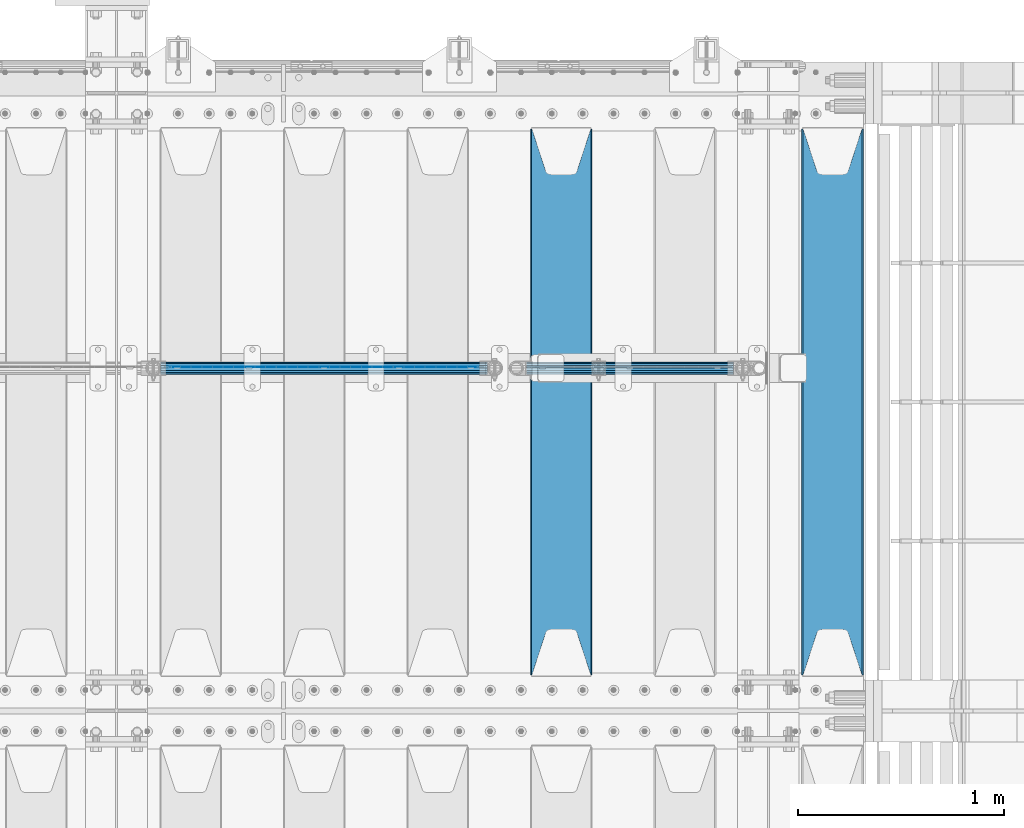
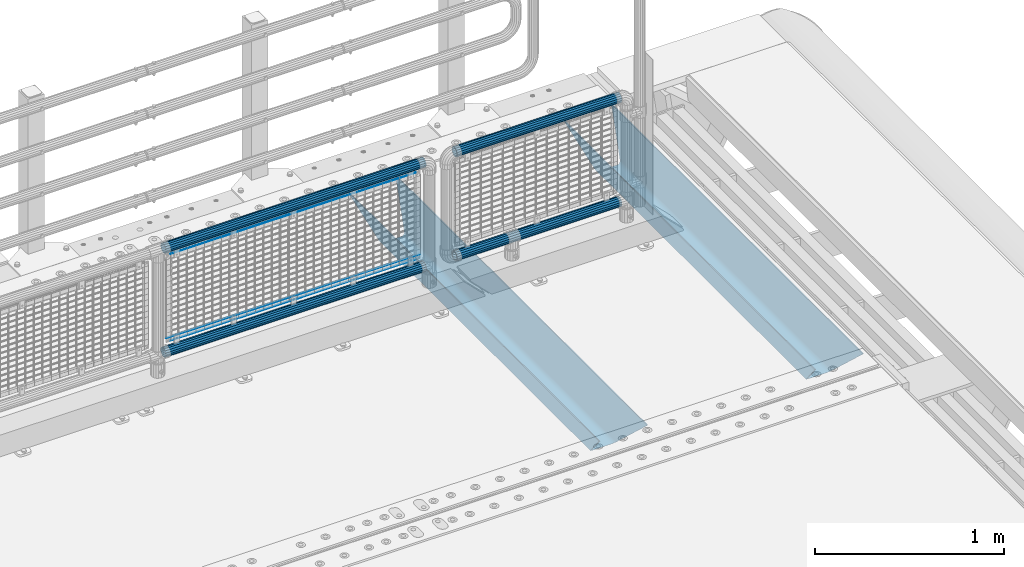
# One storey, part 125 of 240: 9 beams.
"""IFC2X3 building model written with IfcOpenShell, lengths in millimetres."""

from ifc_helpers import new_model, si_unit, frame, origin_with_axes, place, context, subcontext, project, spatial, faceted_brep, material, type_object, element, save


model = new_model("IFC2X3")

# Units and contexts
model_context = context("Model", 3, precision=1e-05, world=origin_with_axes())
body_context = subcontext(model_context, "Body", "Model", "MODEL_VIEW")
ifc_project = project(units=[si_unit("LENGTHUNIT", "METRE", prefix="MILLI"), si_unit("AREAUNIT", "SQUARE_METRE"), si_unit("VOLUMEUNIT", "CUBIC_METRE"), si_unit("MASSUNIT", "GRAM", prefix="KILO"), si_unit("TIMEUNIT", "SECOND"), si_unit("PLANEANGLEUNIT", "RADIAN"), si_unit("SOLIDANGLEUNIT", "STERADIAN"), si_unit("THERMODYNAMICTEMPERATUREUNIT", "DEGREE_CELSIUS"), si_unit("LUMINOUSINTENSITYUNIT", "LUMEN")], contexts=[model_context])

# Site, building, storey
site_placement = place(None, origin_with_axes())
site = spatial("IfcSite", under=ifc_project, at=site_placement, CompositionType="ELEMENT")
building_placement = place(site_placement, origin_with_axes())
building = spatial("IfcBuilding", under=site, at=building_placement, Name="Standard", CompositionType="ELEMENT")
storey_placement = place(building_placement, origin_with_axes())
storey = spatial("IfcBuildingStorey", under=building, at=storey_placement, Name="Undefined", CompositionType="ELEMENT", Elevation=0.0)

# Beams
ifc_material_1 = material(Name="STEEL/S355N")
beam_type_1 = type_object("IfcBeamType", PredefinedType="NOTDEFINED")
beam_1_placement = place(storey_placement, frame((56317.0, 33175.0, -115.0), z_axis=(0.0, 0.0, 1.0), x_axis=(0.0, 1.0, 0.0)))
element("IfcBeam", 1, at=beam_1_placement, inside=storey, type_object=beam_type_1, material=ifc_material_1, context=body_context, shape_type="Brep", body=[
    faceted_brep([(0.0, 150.0, 115.0), (0.0, 143.690000000002, 115.0), (2650.00000000297, 143.690000000002, 115.0), (2650.00000000297, 150.0, 115.0), (2650.00000000297, 142.059565218406, 110.000000003094), (2650.00000000297, 148.369565218403, 110.000000003094), (2441.90079219209, -80.1103600731149, -98.0992078077845), (2437.7588105432, -77.5672621345584, -102.241189456673), (2434.06523489747, -74.4080125315522, -105.934765102404), (2430.9108609509, -70.7102721255724, -109.089139048974), (2428.37322971128, -66.5649389910031, -111.626770288588), (2426.51472138055, -62.0739139532889, -113.485278619323), (2425.38102192092, -57.3475956567636, -114.618978078955), (2424.99999999987, -52.5021667386536, -115.0), (2424.99999999987, 52.5021667386536, -115.0), (2425.38102192092, 57.3475956567636, -114.618978078955), (2426.51472138055, 62.0739139532889, -113.485278619323), (2428.37322971128, 66.5649389910031, -111.626770288588), (2430.9108609509, 70.7102721255724, -109.089139048974), (2434.06523489747, 74.4080125315522, -105.934765102404), (2437.7588105432, 77.5672621345584, -102.241189456673), (2441.90079219209, 80.1103600731149, -98.0992078077846), (2446.38936140512, 81.9747917625791, -93.6106385947584), (2448.2494850041, 76.2713538057287, -91.7505149957729), (2444.62967112263, 74.76777986261, -95.3703288772456), (2441.28936334127, 72.7168944282894, -98.710636658607), (2438.31067330439, 70.1691124903809, -101.689326695487), (2435.76682334748, 67.1870637758839, -104.233176652398), (2433.72034654134, 63.8440531834931, -106.279653458539), (2432.22154950042, 60.2222587982324, -107.778450499454), (2431.30727574265, 56.4107117849126, -108.692724257221), (2430.99999999987, 52.5031078186876, -109.0), (2430.99999999987, -52.5031078186876, -109.0), (2431.30727574265, -56.4107117849126, -108.692724257221), (2432.22154950042, -60.2222587982324, -107.778450499454), (2433.72034654134, -63.8440531834931, -106.279653458539), (2435.76682334748, -67.1870637758839, -104.233176652398), (2438.31067330439, -70.1691124903809, -101.689326695487), (2441.28936334127, -72.7168944282894, -98.7106366586071), (2444.62967112263, -74.76777986261, -95.3703288772457), (2448.2494850041, -76.2713538057287, -91.7505149957729), (2650.00000000297, -142.059565218406, 110.000000003094), (2650.00000000297, -148.369565218403, 110.000000003094), (2446.38936140512, -81.9747917625791, -93.6106385947584), (2650.00000000297, -143.690000000002, 115.0), (2650.00000000297, -150.0, 115.0), (0.0, -143.690000000002, 115.0), (0.0, -150.0, 115.0), (0.0, -148.369565218258, 110.000000002667), (203.610638597427, -81.9747917625791, -93.6106385947584), (208.09920781045, -80.1103600731149, -98.0992078077845), (212.241189459342, -77.5672621345584, -102.241189456673), (215.93476510507, -74.4080125315522, -105.934765102404), (219.089139051641, -70.7102721255724, -109.089139048974), (221.626770291256, -66.5649389910031, -111.626770288588), (223.485278621989, -62.0739139532889, -113.485278619323), (224.618978081624, -57.3475956567636, -114.618978078955), (225.000000002663, -52.5021667386536, -115.0), (225.000000002663, 52.5021667386536, -115.0), (224.618978081624, 57.3475956567636, -114.618978078955), (223.485278621989, 62.0739139532889, -113.485278619323), (221.626770291256, 66.5649389910031, -111.626770288588), (219.089139051641, 70.7102721255724, -109.089139048974), (215.93476510507, 74.4080125315522, -105.934765102404), (212.241189459342, 77.5672621345584, -102.241189456673), (208.09920781045, 80.1103600731149, -98.0992078077846), (203.610638597427, 81.9747917625791, -93.6106385947584), (0.0, 148.369565218258, 110.000000002667), (0.0, 142.05956521826, 110.000000002667), (201.750514998439, 76.2713538057287, -91.7505149957729), (205.370328879908, 74.76777986261, -95.3703288772456), (208.710636661275, 72.7168944282894, -98.710636658607), (211.689326698153, 70.1691124903809, -101.689326695487), (214.233176655063, 67.1870637758839, -104.233176652398), (216.279653461206, 63.8440531834931, -106.279653458539), (217.778450502123, 60.2222587982324, -107.778450499454), (218.692724259887, 56.4107117849126, -108.692724257221), (219.000000002667, 52.5031078186876, -109.0), (219.000000002667, -52.5031078186876, -109.0), (218.692724259887, -56.4107117849126, -108.692724257221), (217.778450502123, -60.2222587982324, -107.778450499454), (216.279653461206, -63.8440531834931, -106.279653458539), (214.233176655063, -67.1870637758839, -104.233176652398), (211.689326698153, -70.1691124903809, -101.689326695487), (208.710636661275, -72.7168944282894, -98.7106366586071), (205.370328879915, -74.76777986261, -95.3703288772457), (201.750514998439, -76.2713538057287, -91.7505149957729), (0.0, -142.05956521826, 110.000000002667)], [[[0, 1, 2, 3]], [[3, 2, 4, 5]], [[6, 7, 8, 9, 10, 11, 12, 13, 14, 15, 16, 17, 18, 19, 20, 21, 22, 5, 4, 23, 24, 25, 26, 27, 28, 29, 30, 31, 32, 33, 34, 35, 36, 37, 38, 39, 40, 41, 42, 43]], [[44, 45, 42, 41]], [[46, 47, 45, 44]], [[43, 42, 45, 47, 48, 49]], [[6, 43, 49, 50]], [[7, 6, 50, 51]], [[8, 7, 51, 52]], [[9, 8, 52, 53]], [[10, 9, 53, 54]], [[11, 10, 54, 55]], [[12, 11, 55, 56]], [[13, 12, 56, 57]], [[14, 13, 57, 58]], [[15, 14, 58, 59]], [[16, 15, 59, 60]], [[17, 16, 60, 61]], [[18, 17, 61, 62]], [[19, 18, 62, 63]], [[20, 19, 63, 64]], [[21, 20, 64, 65]], [[22, 21, 65, 66]], [[0, 3, 5, 22, 66, 67]], [[1, 0, 67, 68]], [[23, 4, 2, 1, 68, 69]], [[24, 23, 69, 70]], [[25, 24, 70, 71]], [[26, 25, 71, 72]], [[27, 26, 72, 73]], [[28, 27, 73, 74]], [[29, 28, 74, 75]], [[30, 29, 75, 76]], [[31, 30, 76, 77]], [[32, 31, 77, 78]], [[33, 32, 78, 79]], [[34, 33, 79, 80]], [[35, 34, 80, 81]], [[36, 35, 81, 82]], [[37, 36, 82, 83]], [[38, 37, 83, 84]], [[39, 38, 84, 85]], [[40, 39, 85, 86]], [[46, 44, 41, 40, 86, 87]], [[47, 46, 87, 48]], [[86, 85, 84, 83, 82, 81, 80, 79, 78, 77, 76, 75, 74, 73, 72, 71, 70, 69, 68, 67, 66, 65, 64, 63, 62, 61, 60, 59, 58, 57, 56, 55, 54, 53, 52, 51, 50, 49, 48, 87]]]),
])
beam_2_placement = place(storey_placement, frame((55000.0, 33175.0, -115.0), z_axis=(0.0, 0.0, 1.0), x_axis=(0.0, 1.0, 0.0)))
element("IfcBeam", 2, at=beam_2_placement, inside=storey, type_object=beam_type_1, material=ifc_material_1, context=body_context, shape_type="Brep", body=[
    faceted_brep([(0.0, 150.0, 115.0), (0.0, 143.690000000002, 115.0), (2650.00000000297, 143.690000000002, 115.0), (2650.00000000297, 150.0, 115.0), (2650.00000000297, 142.059565218406, 110.000000003094), (2650.00000000297, 148.369565218403, 110.000000003094), (2441.90079219209, -80.1103600731149, -98.0992078077845), (2437.7588105432, -77.5672621345584, -102.241189456673), (2434.06523489747, -74.4080125315522, -105.934765102404), (2430.9108609509, -70.7102721255724, -109.089139048974), (2428.37322971128, -66.5649389910031, -111.626770288588), (2426.51472138055, -62.0739139532889, -113.485278619323), (2425.38102192092, -57.3475956567636, -114.618978078955), (2424.99999999987, -52.5021667386536, -115.0), (2424.99999999987, 52.5021667386536, -115.0), (2425.38102192092, 57.3475956567636, -114.618978078955), (2426.51472138055, 62.0739139532889, -113.485278619323), (2428.37322971128, 66.5649389910031, -111.626770288588), (2430.9108609509, 70.7102721255724, -109.089139048974), (2434.06523489747, 74.4080125315522, -105.934765102404), (2437.7588105432, 77.5672621345584, -102.241189456673), (2441.90079219209, 80.1103600731149, -98.0992078077846), (2446.38936140512, 81.9747917625791, -93.6106385947584), (2448.2494850041, 76.2713538057287, -91.7505149957729), (2444.62967112263, 74.76777986261, -95.3703288772456), (2441.28936334127, 72.7168944282894, -98.710636658607), (2438.31067330439, 70.1691124903809, -101.689326695487), (2435.76682334748, 67.1870637758839, -104.233176652398), (2433.72034654134, 63.8440531834931, -106.279653458539), (2432.22154950042, 60.2222587982324, -107.778450499454), (2431.30727574265, 56.4107117849126, -108.692724257221), (2430.99999999987, 52.5031078186876, -109.0), (2430.99999999987, -52.5031078186876, -109.0), (2431.30727574265, -56.4107117849126, -108.692724257221), (2432.22154950042, -60.2222587982324, -107.778450499454), (2433.72034654134, -63.8440531834931, -106.279653458539), (2435.76682334748, -67.1870637758839, -104.233176652398), (2438.31067330439, -70.1691124903809, -101.689326695487), (2441.28936334127, -72.7168944282894, -98.7106366586071), (2444.62967112263, -74.76777986261, -95.3703288772457), (2448.2494850041, -76.2713538057287, -91.7505149957729), (2650.00000000297, -142.059565218406, 110.000000003094), (2650.00000000297, -148.369565218403, 110.000000003094), (2446.38936140512, -81.9747917625791, -93.6106385947584), (2650.00000000297, -143.690000000002, 115.0), (2650.00000000297, -150.0, 115.0), (0.0, -143.690000000002, 115.0), (0.0, -150.0, 115.0), (0.0, -148.369565218258, 110.000000002667), (203.610638597427, -81.9747917625791, -93.6106385947584), (208.09920781045, -80.1103600731149, -98.0992078077845), (212.241189459342, -77.5672621345584, -102.241189456673), (215.93476510507, -74.4080125315522, -105.934765102404), (219.089139051641, -70.7102721255724, -109.089139048974), (221.626770291256, -66.5649389910031, -111.626770288588), (223.485278621989, -62.0739139532889, -113.485278619323), (224.618978081624, -57.3475956567636, -114.618978078955), (225.000000002663, -52.5021667386536, -115.0), (225.000000002663, 52.5021667386536, -115.0), (224.618978081624, 57.3475956567636, -114.618978078955), (223.485278621989, 62.0739139532889, -113.485278619323), (221.626770291256, 66.5649389910031, -111.626770288588), (219.089139051641, 70.7102721255724, -109.089139048974), (215.93476510507, 74.4080125315522, -105.934765102404), (212.241189459342, 77.5672621345584, -102.241189456673), (208.09920781045, 80.1103600731149, -98.0992078077846), (203.610638597427, 81.9747917625791, -93.6106385947584), (0.0, 148.369565218258, 110.000000002667), (0.0, 142.05956521826, 110.000000002667), (201.750514998439, 76.2713538057287, -91.7505149957729), (205.370328879908, 74.76777986261, -95.3703288772456), (208.710636661275, 72.7168944282894, -98.710636658607), (211.689326698153, 70.1691124903809, -101.689326695487), (214.233176655063, 67.1870637758839, -104.233176652398), (216.279653461206, 63.8440531834931, -106.279653458539), (217.778450502123, 60.2222587982324, -107.778450499454), (218.692724259887, 56.4107117849126, -108.692724257221), (219.000000002667, 52.5031078186876, -109.0), (219.000000002667, -52.5031078186876, -109.0), (218.692724259887, -56.4107117849126, -108.692724257221), (217.778450502123, -60.2222587982324, -107.778450499454), (216.279653461206, -63.8440531834931, -106.279653458539), (214.233176655063, -67.1870637758839, -104.233176652398), (211.689326698153, -70.1691124903809, -101.689326695487), (208.710636661275, -72.7168944282894, -98.7106366586071), (205.370328879915, -74.76777986261, -95.3703288772457), (201.750514998439, -76.2713538057287, -91.7505149957729), (0.0, -142.05956521826, 110.000000002667)], [[[0, 1, 2, 3]], [[3, 2, 4, 5]], [[6, 7, 8, 9, 10, 11, 12, 13, 14, 15, 16, 17, 18, 19, 20, 21, 22, 5, 4, 23, 24, 25, 26, 27, 28, 29, 30, 31, 32, 33, 34, 35, 36, 37, 38, 39, 40, 41, 42, 43]], [[44, 45, 42, 41]], [[46, 47, 45, 44]], [[43, 42, 45, 47, 48, 49]], [[6, 43, 49, 50]], [[7, 6, 50, 51]], [[8, 7, 51, 52]], [[9, 8, 52, 53]], [[10, 9, 53, 54]], [[11, 10, 54, 55]], [[12, 11, 55, 56]], [[13, 12, 56, 57]], [[14, 13, 57, 58]], [[15, 14, 58, 59]], [[16, 15, 59, 60]], [[17, 16, 60, 61]], [[18, 17, 61, 62]], [[19, 18, 62, 63]], [[20, 19, 63, 64]], [[21, 20, 64, 65]], [[22, 21, 65, 66]], [[0, 3, 5, 22, 66, 67]], [[1, 0, 67, 68]], [[23, 4, 2, 1, 68, 69]], [[24, 23, 69, 70]], [[25, 24, 70, 71]], [[26, 25, 71, 72]], [[27, 26, 72, 73]], [[28, 27, 73, 74]], [[29, 28, 74, 75]], [[30, 29, 75, 76]], [[31, 30, 76, 77]], [[32, 31, 77, 78]], [[33, 32, 78, 79]], [[34, 33, 79, 80]], [[35, 34, 80, 81]], [[36, 35, 81, 82]], [[37, 36, 82, 83]], [[38, 37, 83, 84]], [[39, 38, 84, 85]], [[40, 39, 85, 86]], [[46, 44, 41, 40, 86, 87]], [[47, 46, 87, 48]], [[86, 85, 84, 83, 82, 81, 80, 79, 78, 77, 76, 75, 74, 73, 72, 71, 70, 69, 68, 67, 66, 65, 64, 63, 62, 61, 60, 59, 58, 57, 56, 55, 54, 53, 52, 51, 50, 49, 48, 87]]]),
])
ifc_material_2 = material(Name="Misc_Undefined")
beam_type_2 = type_object("IfcBeamType", Name="D3", PredefinedType="NOTDEFINED")
beam_3_placement = place(storey_placement, frame((53099.0, 34670.5, 353.020000000001), z_axis=(0.0, 0.0, 1.0), x_axis=(1.0, 0.0, 0.0)))
element("IfcBeam", 3, at=beam_3_placement, inside=storey, type_object=beam_type_2, material=ifc_material_2, ObjectType="D3", context=body_context, shape_type="Brep", body=[
    faceted_brep([(-7.27595761418343e-12, -1.49999999999272, 0.0), (-7.27595761418343e-12, -0.749999999992724, -1.29903810567669), (1498.0, -0.75, -1.29903810567669), (1498.0, -1.5, 0.0), (0.0, 0.750000000007276, -1.29903810567669), (1498.0, 0.75, -1.29903810567663), (0.0, 1.50000000000728, 0.0), (1498.0, 1.5, 0.0), (0.0, 0.750000000007276, 1.29903810567669), (1498.0, 0.75, 1.29903810567669), (-7.27595761418343e-12, -0.749999999992724, 1.29903810567669), (1498.0, -0.75, 1.29903810567669)], [[[0, 1, 2, 3]], [[1, 4, 5, 2]], [[4, 6, 7, 5]], [[6, 8, 9, 7]], [[8, 10, 11, 9]], [[10, 0, 3, 11]], [[5, 7, 9, 11, 3, 2]], [[10, 8, 6, 4, 1, 0]]]),
])
beam_4_placement = place(storey_placement, frame((53074.0, 34670.5, 378.020000000001), z_axis=(0.0, 0.0, 1.0), x_axis=(1.0, 0.0, 0.0)))
element("IfcBeam", 4, at=beam_4_placement, inside=storey, type_object=beam_type_2, material=ifc_material_2, ObjectType="D3", context=body_context, shape_type="Brep", body=[
    faceted_brep([(-7.27595761418343e-12, -1.49999999999272, 0.0), (-7.27595761418343e-12, -0.749999999992724, -1.29903810567669), (1548.0, -0.75, -1.29903810567669), (1548.0, -1.5, 0.0), (0.0, 0.750000000007276, -1.29903810567669), (1548.0, 0.75, -1.29903810567669), (0.0, 1.50000000000728, 0.0), (1548.0, 1.5, 0.0), (0.0, 0.750000000007276, 1.29903810567669), (1548.0, 0.75, 1.29903810567669), (-7.27595761418343e-12, -0.749999999992724, 1.29903810567669), (1548.0, -0.75, 1.29903810567669)], [[[0, 1, 2, 3]], [[1, 4, 5, 2]], [[4, 6, 7, 5]], [[6, 8, 9, 7]], [[8, 10, 11, 9]], [[10, 0, 3, 11]], [[5, 7, 9, 11, 3, 2]], [[10, 8, 6, 4, 1, 0]]]),
])
beam_5_placement = place(storey_placement, frame((53099.0, 34670.5, 913.020000000001), z_axis=(0.0, 0.0, 1.0), x_axis=(1.0, 0.0, 0.0)))
element("IfcBeam", 5, at=beam_5_placement, inside=storey, type_object=beam_type_2, material=ifc_material_2, ObjectType="D3", context=body_context, shape_type="Brep", body=[
    faceted_brep([(-7.27595761418343e-12, -1.49999999999272, 0.0), (-7.27595761418343e-12, -0.749999999992724, -1.29903810567669), (1498.0, -0.75, -1.29903810567669), (1498.0, -1.5, 0.0), (0.0, 0.750000000007276, -1.29903810567669), (1498.0, 0.75, -1.29903810567663), (0.0, 1.50000000000728, 0.0), (1498.0, 1.5, 0.0), (0.0, 0.750000000007276, 1.29903810567669), (1498.0, 0.75, 1.29903810567669), (-7.27595761418343e-12, -0.749999999992724, 1.29903810567669), (1498.0, -0.75, 1.29903810567669)], [[[0, 1, 2, 3]], [[1, 4, 5, 2]], [[4, 6, 7, 5]], [[6, 8, 9, 7]], [[8, 10, 11, 9]], [[10, 0, 3, 11]], [[5, 7, 9, 11, 3, 2]], [[10, 8, 6, 4, 1, 0]]]),
])
ifc_material_3 = material()
beam_type_3 = type_object("IfcBeamType", PredefinedType="NOTDEFINED")
beam_6_placement = place(storey_placement, frame((53053.85, 34664.5, 969.850000000001), z_axis=(0.0, 0.0, 1.0), x_axis=(1.0, 0.0, 0.0)))
element("IfcBeam", 6, at=beam_6_placement, inside=storey, type_object=beam_type_3, material=ifc_material_3, context=body_context, shape_type="Brep", body=[
    faceted_brep([(0.0, -25.3499999999985, 0.0), (0.0, -23.4203461491634, 9.70102501045767), (1588.0, -23.4203461491634, 9.70102501045506), (1588.0, -25.3499999999985, 0.0), (0.0, -17.9251569030821, 17.9251569030821), (1588.0, -17.9251569030821, 17.925156903079), (0.0, -9.70102501045767, 23.4203461491634), (1588.0, -9.70102501045767, 23.4203461491611), (0.0, 0.0, 25.3499999999985), (1588.0, 0.0, 25.35), (0.0, 9.70102501045767, 23.4203461491634), (1588.0, 9.70102501045767, 23.4203461491611), (0.0, 17.9251569030821, 17.9251569030821), (1588.0, 17.9251569030821, 17.925156903079), (0.0, 23.4203461491634, 9.70102501045767), (1588.0, 23.4203461491634, 9.70102501045506), (0.0, 25.3499999999985, 0.0), (1588.0, 25.3499999999985, 0.0), (0.0, 23.4203461491634, -9.70102501045767), (1588.0, 23.4203461491634, -9.70102501045506), (0.0, 17.9251569030821, -17.9251569030821), (1588.0, 17.9251569030821, -17.925156903079), (0.0, 9.70102501045767, -23.4203461491634), (1588.0, 9.70102501045767, -23.4203461491611), (0.0, 0.0, -25.3499999999985), (1588.0, 0.0, -25.35), (0.0, -9.70102501045767, -23.4203461491634), (1588.0, -9.70102501045767, -23.4203461491611), (0.0, -17.9251569030821, -17.9251569030821), (1588.0, -17.9251569030821, -17.925156903079), (0.0, -23.4203461491634, -9.70102501045767), (1588.0, -23.4203461491634, -9.70102501045506), (0.0, -30.1500000000015, 0.0), (0.0, -27.8549679052157, -11.5379054858058), (1588.0, -27.8549679052157, -11.5379054858075), (1588.0, -30.1500000000015, 0.0), (0.0, -21.3192694527752, -21.3192694527752), (1588.0, -21.3192694527752, -21.3192694527744), (0.0, -11.5379054858058, -27.8549679052157), (1588.0, -11.5379054858058, -27.8549679052153), (0.0, 0.0, -30.1500000000015), (1588.0, 0.0, -30.15), (0.0, 11.5379054858058, -27.8549679052157), (1588.0, 11.5379054858058, -27.8549679052153), (0.0, 21.3192694527752, -21.3192694527752), (1588.0, 21.3192694527752, -21.3192694527744), (0.0, 27.8549679052157, -11.5379054858058), (1588.0, 27.8549679052157, -11.5379054858074), (0.0, 30.1500000000015, 0.0), (1588.0, 30.1500000000015, 0.0), (0.0, 27.8549679052157, 11.5379054858058), (1588.0, 27.8549679052157, 11.5379054858074), (0.0, 21.3192694527752, 21.3192694527752), (1588.0, 21.3192694527752, 21.3192694527744), (0.0, 11.5379054858058, 27.8549679052157), (1588.0, 11.5379054858058, 27.8549679052153), (0.0, 0.0, 30.1500000000015), (1588.0, 0.0, 30.15), (0.0, -11.5379054858058, 27.8549679052157), (1588.0, -11.5379054858058, 27.8549679052153), (0.0, -21.3192694527752, 21.3192694527752), (1588.0, -21.3192694527752, 21.3192694527744), (0.0, -27.8549679052157, 11.5379054858058), (1588.0, -27.8549679052157, 11.5379054858074)], [[[0, 1, 2, 3]], [[1, 4, 5, 2]], [[4, 6, 7, 5]], [[6, 8, 9, 7]], [[8, 10, 11, 9]], [[10, 12, 13, 11]], [[12, 14, 15, 13]], [[14, 16, 17, 15]], [[16, 18, 19, 17]], [[18, 20, 21, 19]], [[20, 22, 23, 21]], [[22, 24, 25, 23]], [[24, 26, 27, 25]], [[26, 28, 29, 27]], [[28, 30, 31, 29]], [[30, 0, 3, 31]], [[32, 33, 34, 35]], [[33, 36, 37, 34]], [[36, 38, 39, 37]], [[38, 40, 41, 39]], [[40, 42, 43, 41]], [[42, 44, 45, 43]], [[44, 46, 47, 45]], [[46, 48, 49, 47]], [[48, 50, 51, 49]], [[50, 52, 53, 51]], [[52, 54, 55, 53]], [[54, 56, 57, 55]], [[56, 58, 59, 57]], [[58, 60, 61, 59]], [[60, 62, 63, 61]], [[62, 32, 35, 63]], [[37, 39, 41, 43, 45, 47, 49, 51, 53, 55, 57, 59, 61, 63, 35, 34], [5, 7, 9, 11, 13, 15, 17, 19, 21, 23, 25, 27, 29, 31, 3, 2]], [[62, 60, 58, 56, 54, 52, 50, 48, 46, 44, 42, 40, 38, 36, 33, 32], [30, 28, 26, 24, 22, 20, 18, 16, 14, 12, 10, 8, 6, 4, 1, 0]]]),
])
beam_7_placement = place(storey_placement, frame((53053.85, 34664.5, 298.170000000003), z_axis=(0.0, 0.0, 1.0), x_axis=(1.0, 0.0, 0.0)))
element("IfcBeam", 7, at=beam_7_placement, inside=storey, type_object=beam_type_3, material=ifc_material_3, context=body_context, shape_type="Brep", body=[
    faceted_brep([(0.0, -25.3499999999985, 0.0), (0.0, -23.4203461491634, 9.70102501045767), (1588.0, -23.4203461491634, 9.70102501045506), (1588.0, -25.3499999999985, 0.0), (0.0, -17.9251569030821, 17.9251569030821), (1588.0, -17.9251569030821, 17.925156903079), (0.0, -9.70102501045767, 23.4203461491634), (1588.0, -9.70102501045767, 23.4203461491611), (0.0, 0.0, 25.3499999999985), (1588.0, 0.0, 25.35), (0.0, 9.70102501045767, 23.4203461491634), (1588.0, 9.70102501045767, 23.4203461491611), (0.0, 17.9251569030821, 17.9251569030821), (1588.0, 17.9251569030821, 17.925156903079), (0.0, 23.4203461491634, 9.70102501045767), (1588.0, 23.4203461491634, 9.70102501045506), (0.0, 25.3499999999985, 0.0), (1588.0, 25.3499999999985, 0.0), (0.0, 23.4203461491634, -9.70102501045767), (1588.0, 23.4203461491634, -9.70102501045506), (0.0, 17.9251569030821, -17.9251569030821), (1588.0, 17.9251569030821, -17.925156903079), (0.0, 9.70102501045767, -23.4203461491634), (1588.0, 9.70102501045767, -23.4203461491611), (0.0, 0.0, -25.3499999999985), (1588.0, 0.0, -25.35), (0.0, -9.70102501045767, -23.4203461491634), (1588.0, -9.70102501045767, -23.4203461491611), (0.0, -17.9251569030821, -17.9251569030821), (1588.0, -17.9251569030821, -17.925156903079), (0.0, -23.4203461491634, -9.70102501045767), (1588.0, -23.4203461491634, -9.70102501045506), (0.0, -30.1500000000015, 0.0), (0.0, -27.8549679052157, -11.5379054858058), (1588.0, -27.8549679052157, -11.5379054858075), (1588.0, -30.1500000000015, 0.0), (0.0, -21.3192694527752, -21.3192694527752), (1588.0, -21.3192694527752, -21.3192694527744), (0.0, -11.5379054858058, -27.8549679052157), (1588.0, -11.5379054858058, -27.8549679052153), (0.0, 0.0, -30.1500000000015), (1588.0, 0.0, -30.15), (0.0, 11.5379054858058, -27.8549679052157), (1588.0, 11.5379054858058, -27.8549679052153), (0.0, 21.3192694527752, -21.3192694527752), (1588.0, 21.3192694527752, -21.3192694527744), (0.0, 27.8549679052157, -11.5379054858058), (1588.0, 27.8549679052157, -11.5379054858074), (0.0, 30.1500000000015, 0.0), (1588.0, 30.1500000000015, 0.0), (0.0, 27.8549679052157, 11.5379054858058), (1588.0, 27.8549679052157, 11.5379054858074), (0.0, 21.3192694527752, 21.3192694527752), (1588.0, 21.3192694527752, 21.3192694527744), (0.0, 11.5379054858058, 27.8549679052157), (1588.0, 11.5379054858058, 27.8549679052153), (0.0, 0.0, 30.1500000000015), (1588.0, 0.0, 30.15), (0.0, -11.5379054858058, 27.8549679052157), (1588.0, -11.5379054858058, 27.8549679052153), (0.0, -21.3192694527752, 21.3192694527752), (1588.0, -21.3192694527752, 21.3192694527744), (0.0, -27.8549679052157, 11.5379054858058), (1588.0, -27.8549679052157, 11.5379054858074)], [[[0, 1, 2, 3]], [[1, 4, 5, 2]], [[4, 6, 7, 5]], [[6, 8, 9, 7]], [[8, 10, 11, 9]], [[10, 12, 13, 11]], [[12, 14, 15, 13]], [[14, 16, 17, 15]], [[16, 18, 19, 17]], [[18, 20, 21, 19]], [[20, 22, 23, 21]], [[22, 24, 25, 23]], [[24, 26, 27, 25]], [[26, 28, 29, 27]], [[28, 30, 31, 29]], [[30, 0, 3, 31]], [[32, 33, 34, 35]], [[33, 36, 37, 34]], [[36, 38, 39, 37]], [[38, 40, 41, 39]], [[40, 42, 43, 41]], [[42, 44, 45, 43]], [[44, 46, 47, 45]], [[46, 48, 49, 47]], [[48, 50, 51, 49]], [[50, 52, 53, 51]], [[52, 54, 55, 53]], [[54, 56, 57, 55]], [[56, 58, 59, 57]], [[58, 60, 61, 59]], [[60, 62, 63, 61]], [[62, 32, 35, 63]], [[37, 39, 41, 43, 45, 47, 49, 51, 53, 55, 57, 59, 61, 63, 35, 34], [5, 7, 9, 11, 13, 15, 17, 19, 21, 23, 25, 27, 29, 31, 3, 2]], [[62, 60, 58, 56, 54, 52, 50, 48, 46, 44, 42, 40, 38, 36, 33, 32], [30, 28, 26, 24, 22, 20, 18, 16, 14, 12, 10, 8, 6, 4, 1, 0]]]),
])
beam_8_placement = place(storey_placement, frame((54831.6, 34664.5, 298.170000000001), z_axis=(0.0, 0.0, 1.0), x_axis=(1.0, 0.0, 0.0)))
element("IfcBeam", 8, at=beam_8_placement, inside=storey, type_object=beam_type_3, material=ifc_material_3, context=body_context, shape_type="Brep", body=[
    faceted_brep([(0.0, -25.3499999999985, 0.0), (0.0, -23.4203461491634, 9.70102501045767), (1005.0, -23.4203461491634, 9.70102501045506), (1005.0, -25.3499999999985, 0.0), (0.0, -17.9251569030821, 17.9251569030821), (1005.0, -17.9251569030821, 17.925156903079), (0.0, -9.70102501045767, 23.4203461491634), (1005.0, -9.70102501045767, 23.4203461491611), (0.0, 0.0, 25.3499999999985), (1005.0, 0.0, 25.35), (0.0, 9.70102501045767, 23.4203461491634), (1005.0, 9.70102501045767, 23.4203461491611), (0.0, 17.9251569030821, 17.9251569030821), (1005.0, 17.9251569030821, 17.925156903079), (0.0, 23.4203461491634, 9.70102501045767), (1005.0, 23.4203461491634, 9.701025010455), (0.0, 25.3499999999985, 0.0), (1005.0, 25.3499999999985, 0.0), (0.0, 23.4203461491634, -9.70102501045767), (1005.0, 23.4203461491634, -9.70102501045506), (0.0, 17.9251569030821, -17.9251569030821), (1005.0, 17.9251569030821, -17.925156903079), (0.0, 9.70102501045767, -23.4203461491634), (1005.0, 9.70102501045767, -23.4203461491611), (0.0, 0.0, -25.3499999999985), (1005.0, 0.0, -25.35), (0.0, -9.70102501045767, -23.4203461491634), (1005.0, -9.70102501045767, -23.4203461491611), (0.0, -17.9251569030821, -17.9251569030821), (1005.0, -17.9251569030821, -17.925156903079), (0.0, -23.4203461491634, -9.70102501045767), (1005.0, -23.4203461491634, -9.701025010455), (0.0, -30.1500000000015, 0.0), (0.0, -27.8549679052157, -11.5379054858058), (1005.0, -27.8549679052157, -11.5379054858075), (1005.0, -30.1500000000015, 0.0), (0.0, -21.3192694527752, -21.3192694527752), (1005.0, -21.3192694527752, -21.3192694527744), (0.0, -11.5379054858058, -27.8549679052157), (1005.0, -11.5379054858058, -27.8549679052153), (0.0, 0.0, -30.1500000000015), (1005.0, 0.0, -30.15), (0.0, 11.5379054858058, -27.8549679052157), (1005.0, 11.5379054858058, -27.8549679052153), (0.0, 21.3192694527752, -21.3192694527752), (1005.0, 21.3192694527752, -21.3192694527744), (0.0, 27.8549679052157, -11.5379054858058), (1005.0, 27.8549679052157, -11.5379054858075), (0.0, 30.1500000000015, 0.0), (1005.0, 30.1500000000015, 0.0), (0.0, 27.8549679052157, 11.5379054858058), (1005.0, 27.8549679052157, 11.5379054858075), (0.0, 21.3192694527752, 21.3192694527752), (1005.0, 21.3192694527752, 21.3192694527744), (0.0, 11.5379054858058, 27.8549679052157), (1005.0, 11.5379054858058, 27.8549679052153), (0.0, 0.0, 30.1500000000015), (1005.0, 0.0, 30.15), (0.0, -11.5379054858058, 27.8549679052157), (1005.0, -11.5379054858058, 27.8549679052153), (0.0, -21.3192694527752, 21.3192694527752), (1005.0, -21.3192694527752, 21.3192694527744), (0.0, -27.8549679052157, 11.5379054858058), (1005.0, -27.8549679052157, 11.5379054858075)], [[[0, 1, 2, 3]], [[1, 4, 5, 2]], [[4, 6, 7, 5]], [[6, 8, 9, 7]], [[8, 10, 11, 9]], [[10, 12, 13, 11]], [[12, 14, 15, 13]], [[14, 16, 17, 15]], [[16, 18, 19, 17]], [[18, 20, 21, 19]], [[20, 22, 23, 21]], [[22, 24, 25, 23]], [[24, 26, 27, 25]], [[26, 28, 29, 27]], [[28, 30, 31, 29]], [[30, 0, 3, 31]], [[32, 33, 34, 35]], [[33, 36, 37, 34]], [[36, 38, 39, 37]], [[38, 40, 41, 39]], [[40, 42, 43, 41]], [[42, 44, 45, 43]], [[44, 46, 47, 45]], [[46, 48, 49, 47]], [[48, 50, 51, 49]], [[50, 52, 53, 51]], [[52, 54, 55, 53]], [[54, 56, 57, 55]], [[56, 58, 59, 57]], [[58, 60, 61, 59]], [[60, 62, 63, 61]], [[62, 32, 35, 63]], [[37, 39, 41, 43, 45, 47, 49, 51, 53, 55, 57, 59, 61, 63, 35, 34], [5, 7, 9, 11, 13, 15, 17, 19, 21, 23, 25, 27, 29, 31, 3, 2]], [[62, 60, 58, 56, 54, 52, 50, 48, 46, 44, 42, 40, 38, 36, 33, 32], [30, 28, 26, 24, 22, 20, 18, 16, 14, 12, 10, 8, 6, 4, 1, 0]]]),
])
beam_9_placement = place(storey_placement, frame((54831.0, 34664.5, 969.85), z_axis=(0.0, 0.0, 1.0), x_axis=(1.0, 0.0, 0.0)))
element("IfcBeam", 9, at=beam_9_placement, inside=storey, type_object=beam_type_3, material=ifc_material_3, context=body_context, shape_type="Brep", body=[
    faceted_brep([(0.0, -25.3499999999985, 0.0), (0.0, -23.4203461491634, 9.70102501045767), (1005.0, -23.4203461491634, 9.70102501045506), (1005.0, -25.3499999999985, 0.0), (0.0, -17.9251569030821, 17.9251569030821), (1005.0, -17.9251569030821, 17.925156903079), (0.0, -9.70102501045767, 23.4203461491634), (1005.0, -9.70102501045767, 23.4203461491611), (0.0, 0.0, 25.3499999999985), (1005.0, 0.0, 25.35), (0.0, 9.70102501045767, 23.4203461491634), (1005.0, 9.70102501045767, 23.4203461491611), (0.0, 17.9251569030821, 17.9251569030821), (1005.0, 17.9251569030821, 17.925156903079), (0.0, 23.4203461491634, 9.70102501045767), (1005.0, 23.4203461491634, 9.701025010455), (0.0, 25.3499999999985, 0.0), (1005.0, 25.3499999999985, 0.0), (0.0, 23.4203461491634, -9.70102501045767), (1005.0, 23.4203461491634, -9.70102501045506), (0.0, 17.9251569030821, -17.9251569030821), (1005.0, 17.9251569030821, -17.925156903079), (0.0, 9.70102501045767, -23.4203461491634), (1005.0, 9.70102501045767, -23.4203461491611), (0.0, 0.0, -25.3499999999985), (1005.0, 0.0, -25.35), (0.0, -9.70102501045767, -23.4203461491634), (1005.0, -9.70102501045767, -23.4203461491611), (0.0, -17.9251569030821, -17.9251569030821), (1005.0, -17.9251569030821, -17.925156903079), (0.0, -23.4203461491634, -9.70102501045767), (1005.0, -23.4203461491634, -9.701025010455), (0.0, -30.1500000000015, 0.0), (0.0, -27.8549679052157, -11.5379054858058), (1005.0, -27.8549679052157, -11.5379054858075), (1005.0, -30.1500000000015, 0.0), (0.0, -21.3192694527752, -21.3192694527752), (1005.0, -21.3192694527752, -21.3192694527744), (0.0, -11.5379054858058, -27.8549679052157), (1005.0, -11.5379054858058, -27.8549679052153), (0.0, 0.0, -30.1500000000015), (1005.0, 0.0, -30.15), (0.0, 11.5379054858058, -27.8549679052157), (1005.0, 11.5379054858058, -27.8549679052153), (0.0, 21.3192694527752, -21.3192694527752), (1005.0, 21.3192694527752, -21.3192694527744), (0.0, 27.8549679052157, -11.5379054858058), (1005.0, 27.8549679052157, -11.5379054858075), (0.0, 30.1500000000015, 0.0), (1005.0, 30.1500000000015, 0.0), (0.0, 27.8549679052157, 11.5379054858058), (1005.0, 27.8549679052157, 11.5379054858075), (0.0, 21.3192694527752, 21.3192694527752), (1005.0, 21.3192694527752, 21.3192694527744), (0.0, 11.5379054858058, 27.8549679052157), (1005.0, 11.5379054858058, 27.8549679052153), (0.0, 0.0, 30.1500000000015), (1005.0, 0.0, 30.15), (0.0, -11.5379054858058, 27.8549679052157), (1005.0, -11.5379054858058, 27.8549679052153), (0.0, -21.3192694527752, 21.3192694527752), (1005.0, -21.3192694527752, 21.3192694527744), (0.0, -27.8549679052157, 11.5379054858058), (1005.0, -27.8549679052157, 11.5379054858075)], [[[0, 1, 2, 3]], [[1, 4, 5, 2]], [[4, 6, 7, 5]], [[6, 8, 9, 7]], [[8, 10, 11, 9]], [[10, 12, 13, 11]], [[12, 14, 15, 13]], [[14, 16, 17, 15]], [[16, 18, 19, 17]], [[18, 20, 21, 19]], [[20, 22, 23, 21]], [[22, 24, 25, 23]], [[24, 26, 27, 25]], [[26, 28, 29, 27]], [[28, 30, 31, 29]], [[30, 0, 3, 31]], [[32, 33, 34, 35]], [[33, 36, 37, 34]], [[36, 38, 39, 37]], [[38, 40, 41, 39]], [[40, 42, 43, 41]], [[42, 44, 45, 43]], [[44, 46, 47, 45]], [[46, 48, 49, 47]], [[48, 50, 51, 49]], [[50, 52, 53, 51]], [[52, 54, 55, 53]], [[54, 56, 57, 55]], [[56, 58, 59, 57]], [[58, 60, 61, 59]], [[60, 62, 63, 61]], [[62, 32, 35, 63]], [[37, 39, 41, 43, 45, 47, 49, 51, 53, 55, 57, 59, 61, 63, 35, 34], [5, 7, 9, 11, 13, 15, 17, 19, 21, 23, 25, 27, 29, 31, 3, 2]], [[62, 60, 58, 56, 54, 52, 50, 48, 46, 44, 42, 40, 38, 36, 33, 32], [30, 28, 26, 24, 22, 20, 18, 16, 14, 12, 10, 8, 6, 4, 1, 0]]]),
])

save(model, "model.ifc")
